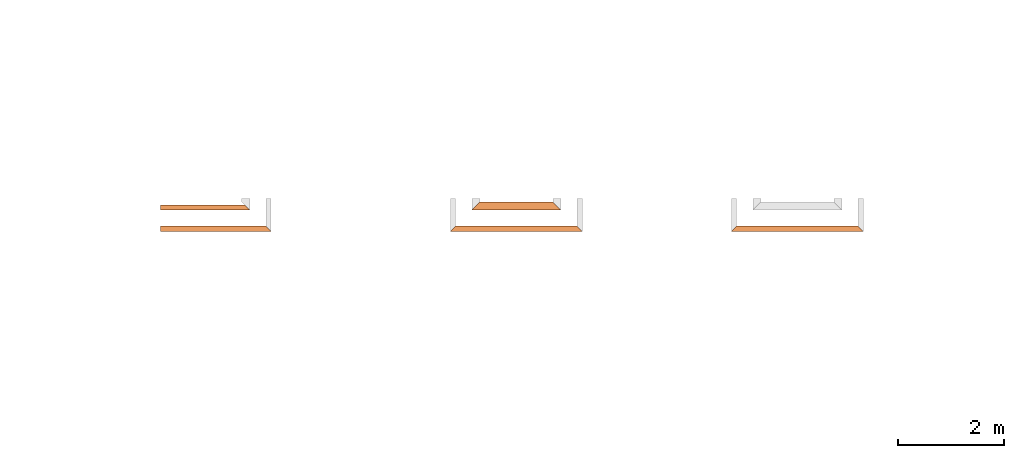
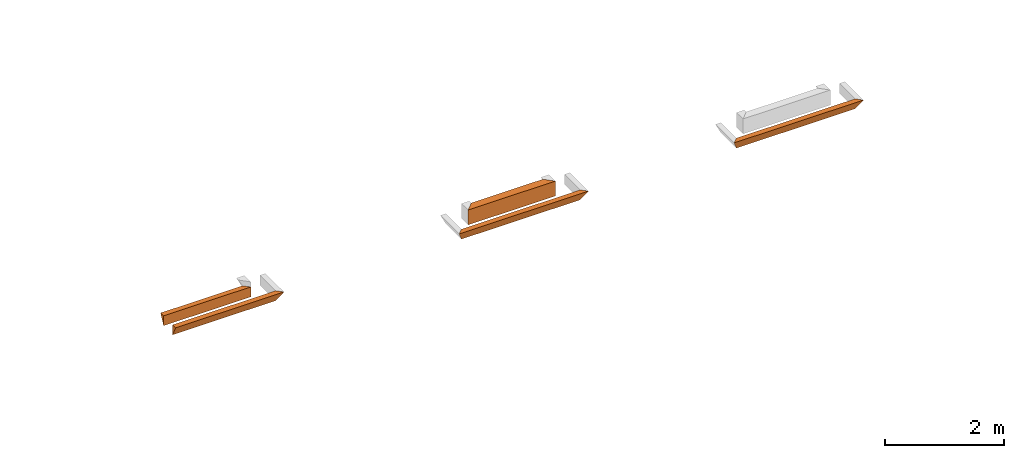
# One storey, part 2 of 8: 5 proxies.
"""IFC4 building model written with IfcOpenShell, lengths in feet."""

from ifc_helpers import new_model, entity, si_unit, converted_unit, derived_unit, direction, frame, origin, place, context, subcontext, project, spatial, type_object, element, save


model = new_model("IFC4")

# Units and contexts
model_context_1 = context("Model", 3, precision=0.0001, world=origin(), true_north=direction((6.12303176911189e-17, 1.0)))
model_context_2 = context("Model", 3, precision=0.0001, world=origin(), true_north=direction((6.12303176911189e-17, 1.0)))
body_context = subcontext(model_context_2, "Body", "Model", "MODEL_VIEW")
ifc_project = project(units=[converted_unit("LENGTHUNIT", "FOOT", entity("IfcRatioMeasure", 0.3048), si_unit("LENGTHUNIT", "METRE"), dimensions=[1, 0, 0, 0, 0, 0, 0]), converted_unit("AREAUNIT", "SQUARE FOOT", entity("IfcRatioMeasure", 0.09290304), si_unit("AREAUNIT", "SQUARE_METRE"), dimensions=[2, 0, 0, 0, 0, 0, 0]), converted_unit("VOLUMEUNIT", "CUBIC FOOT", entity("IfcRatioMeasure", 0.028316846592), si_unit("VOLUMEUNIT", "CUBIC_METRE"), dimensions=[3, 0, 0, 0, 0, 0, 0]), converted_unit("PLANEANGLEUNIT", "DEGREE", entity("IfcRatioMeasure", 0.0174532925199433), si_unit("PLANEANGLEUNIT", "RADIAN"), dimensions=[0, 0, 0, 0, 0, 0, 0]), si_unit("MASSUNIT", "GRAM", prefix="KILO"), derived_unit("MASSDENSITYUNIT", [(si_unit("MASSUNIT", "GRAM", prefix="KILO"), 1), (si_unit("LENGTHUNIT", "METRE"), -3)]), derived_unit("MOMENTOFINERTIAUNIT", [(si_unit("LENGTHUNIT", "METRE"), 4)]), si_unit("TIMEUNIT", "SECOND"), si_unit("FREQUENCYUNIT", "HERTZ"), si_unit("THERMODYNAMICTEMPERATUREUNIT", "DEGREE_CELSIUS"), derived_unit("THERMALTRANSMITTANCEUNIT", [(si_unit("MASSUNIT", "GRAM", prefix="KILO"), 1), (si_unit("THERMODYNAMICTEMPERATUREUNIT", "KELVIN"), -1), (si_unit("TIMEUNIT", "SECOND"), -3)]), derived_unit("VOLUMETRICFLOWRATEUNIT", [(si_unit("LENGTHUNIT", "METRE"), 3), (si_unit("TIMEUNIT", "SECOND"), -1)]), si_unit("ELECTRICCURRENTUNIT", "AMPERE"), si_unit("ELECTRICVOLTAGEUNIT", "VOLT"), si_unit("POWERUNIT", "WATT"), si_unit("FORCEUNIT", "NEWTON"), si_unit("ILLUMINANCEUNIT", "LUX"), si_unit("LUMINOUSFLUXUNIT", "LUMEN"), si_unit("LUMINOUSINTENSITYUNIT", "CANDELA"), derived_unit("USERDEFINED", [(si_unit("MASSUNIT", "GRAM", prefix="KILO"), -1), (si_unit("LENGTHUNIT", "METRE"), -2), (si_unit("TIMEUNIT", "SECOND"), 3), (si_unit("LUMINOUSFLUXUNIT", "LUMEN"), 1)]), derived_unit("LINEARVELOCITYUNIT", [(si_unit("LENGTHUNIT", "METRE"), 1), (si_unit("TIMEUNIT", "SECOND"), -1)]), si_unit("PRESSUREUNIT", "PASCAL"), derived_unit("USERDEFINED", [(si_unit("LENGTHUNIT", "METRE"), -2), (si_unit("MASSUNIT", "GRAM", prefix="KILO"), 1), (si_unit("TIMEUNIT", "SECOND"), -2)]), derived_unit("LINEARFORCEUNIT", [(si_unit("MASSUNIT", "GRAM", prefix="KILO"), 1), (si_unit("LENGTHUNIT", "METRE"), 1), (si_unit("TIMEUNIT", "SECOND"), -2), (si_unit("LENGTHUNIT", "METRE"), -1)]), derived_unit("PLANARFORCEUNIT", [(si_unit("MASSUNIT", "GRAM", prefix="KILO"), 1), (si_unit("LENGTHUNIT", "METRE"), 1), (si_unit("TIMEUNIT", "SECOND"), -2), (si_unit("LENGTHUNIT", "METRE"), -2)])], contexts=[model_context_1])

# Site, building, storey
site_placement = place(None, origin())
site = spatial("IfcSite", under=ifc_project, at=site_placement, CompositionType="ELEMENT")
building_placement = place(site_placement, origin())
building = spatial("IfcBuilding", under=site, at=building_placement, CompositionType="ELEMENT")
storey_placement = place(building_placement, frame((0.0, 0.0, -12.6666666666667)))
storey = spatial("IfcBuildingStorey", under=building, at=storey_placement, Name="BASEMENT", CompositionType="ELEMENT", Elevation=-12.6666666666667)

# Proxies
building_element_proxy_type_1 = type_object("IfcBuildingElementProxyType", PredefinedType="NOTDEFINED")
proxy_1_placement = place(storey_placement, frame((-253.238160457323, 957.231726549317, 11.5833333333333)))
cartesian_point_1 = entity("IfcCartesianPoint", [5.54166663846127, 0.0, 0.0])
vertex_point_1 = entity("IfcVertexPoint", cartesian_point_1)
cartesian_point_2 = entity("IfcCartesianPoint", [5.21181447152242, 0.329852166938849, 0.65970433387773])
vertex_point_2 = entity("IfcVertexPoint", cartesian_point_2)
edge_curve_1 = entity("IfcEdgeCurve", vertex_point_1, vertex_point_2, entity("IfcTrimmedCurve", entity("IfcLine", cartesian_point_1, entity("IfcVector", entity("IfcDirection", [-0.408248290463852, 0.408248290463852, 0.816496580927737]), 1.0)), [cartesian_point_1], [cartesian_point_2], True, "CARTESIAN"), True)
cartesian_point_3 = entity("IfcCartesianPoint", [5.54166663846115, 0.0, 0.666576254022283])
vertex_point_3 = entity("IfcVertexPoint", cartesian_point_3)
edge_curve_2 = entity("IfcEdgeCurve", vertex_point_2, vertex_point_3, entity("IfcTrimmedCurve", entity("IfcLine", cartesian_point_2, entity("IfcVector", entity("IfcDirection", [0.707030067676022, -0.707030067676022, 0.0147297930765838]), 1.0)), [cartesian_point_2], [cartesian_point_3], True, "CARTESIAN"), True)
edge_curve_3 = entity("IfcEdgeCurve", vertex_point_3, vertex_point_1, entity("IfcTrimmedCurve", entity("IfcLine", cartesian_point_3, entity("IfcVector", entity("IfcDirection", [0.0, 0.0, -1.0]), 1.0)), [cartesian_point_3], [cartesian_point_1], True, "CARTESIAN"), True)
cartesian_point_4 = entity("IfcCartesianPoint", [0.0, 0.329852166939077, 0.659704333877725])
vertex_point_4 = entity("IfcVertexPoint", cartesian_point_4)
cartesian_point_5 = entity("IfcCartesianPoint", [0.0, 0.0, 0.0])
vertex_point_5 = entity("IfcVertexPoint", cartesian_point_5)
edge_curve_4 = entity("IfcEdgeCurve", vertex_point_4, vertex_point_5, entity("IfcTrimmedCurve", entity("IfcLine", cartesian_point_4, entity("IfcVector", entity("IfcDirection", [0.0, -0.447213595499946, -0.894427190999922]), 1.0)), [cartesian_point_4], [cartesian_point_5], True, "CARTESIAN"), True)
cartesian_point_6 = entity("IfcCartesianPoint", [0.0, 0.0, 0.666576254022285])
vertex_point_6 = entity("IfcVertexPoint", cartesian_point_6)
edge_curve_5 = entity("IfcEdgeCurve", vertex_point_5, vertex_point_6, entity("IfcTrimmedCurve", entity("IfcLine", cartesian_point_5, entity("IfcVector", entity("IfcDirection", [0.0, 0.0, 1.0]), 1.0)), [cartesian_point_5], [cartesian_point_6], True, "CARTESIAN"), True)
edge_curve_6 = entity("IfcEdgeCurve", vertex_point_6, vertex_point_4, entity("IfcTrimmedCurve", entity("IfcLine", cartesian_point_6, entity("IfcVector", entity("IfcDirection", [0.0, 0.999783056728112, -0.0208288136818321]), 1.0)), [cartesian_point_6], [cartesian_point_4], True, "CARTESIAN"), True)
ifc_direction_1 = entity("IfcDirection", [-1.0, 0.0, 0.0])
ifc_direction_2 = entity("IfcDirection", [0.0, -1.0, 0.0])
edge_curve_7 = entity("IfcEdgeCurve", vertex_point_1, vertex_point_5, entity("IfcTrimmedCurve", entity("IfcLine", cartesian_point_1, entity("IfcVector", ifc_direction_1, 1.0)), [cartesian_point_1], [cartesian_point_5], True, "CARTESIAN"), True)
edge_curve_8 = entity("IfcEdgeCurve", vertex_point_4, vertex_point_2, entity("IfcTrimmedCurve", entity("IfcLine", cartesian_point_4, entity("IfcVector", entity("IfcDirection", [1.0, 0.0, 0.0]), 1.0)), [cartesian_point_4], [cartesian_point_2], True, "CARTESIAN"), True)
edge_curve_9 = entity("IfcEdgeCurve", vertex_point_3, vertex_point_6, entity("IfcTrimmedCurve", entity("IfcLine", cartesian_point_3, entity("IfcVector", ifc_direction_1, 1.0)), [cartesian_point_3], [cartesian_point_6], True, "CARTESIAN"), True)
element("IfcBuildingElementProxy", 1, at=proxy_1_placement, inside=storey, type_object=building_element_proxy_type_1, PredefinedType="NOTDEFINED", context=body_context, shape_type="AdvancedBrep", body=[
    entity("IfcAdvancedBrep", entity("IfcClosedShell", [entity("IfcAdvancedFace", [entity("IfcFaceOuterBound", entity("IfcEdgeLoop", [entity("IfcOrientedEdge", None, None, edge_curve_1, True), entity("IfcOrientedEdge", None, None, edge_curve_2, True), entity("IfcOrientedEdge", None, None, edge_curve_3, True)]), True)], entity("IfcPlane", entity("IfcAxis2Placement3D", entity("IfcCartesianPoint", [5.54166663846127, 0.0, 2.0]), entity("IfcDirection", [0.707106781186562, 0.707106781186533, 0.0]), entity("IfcDirection", [-0.707106781186533, 0.707106781186562, 0.0]))), True), entity("IfcAdvancedFace", [entity("IfcFaceOuterBound", entity("IfcEdgeLoop", [entity("IfcOrientedEdge", None, None, edge_curve_4, True), entity("IfcOrientedEdge", None, None, edge_curve_5, True), entity("IfcOrientedEdge", None, None, edge_curve_6, True)]), True)], entity("IfcPlane", entity("IfcAxis2Placement3D", cartesian_point_5, ifc_direction_1, ifc_direction_2)), True), entity("IfcAdvancedFace", [entity("IfcFaceOuterBound", entity("IfcEdgeLoop", [entity("IfcOrientedEdge", None, None, edge_curve_7, True), entity("IfcOrientedEdge", None, None, edge_curve_4, False), entity("IfcOrientedEdge", None, None, edge_curve_8, True), entity("IfcOrientedEdge", None, None, edge_curve_1, False)]), True)], entity("IfcPlane", entity("IfcAxis2Placement3D", cartesian_point_1, entity("IfcDirection", [0.0, 0.894427190999915, -0.447213595499961]), ifc_direction_1)), True), entity("IfcAdvancedFace", [entity("IfcFaceOuterBound", entity("IfcEdgeLoop", [entity("IfcOrientedEdge", None, None, edge_curve_7, False), entity("IfcOrientedEdge", None, None, edge_curve_3, False), entity("IfcOrientedEdge", None, None, edge_curve_9, True), entity("IfcOrientedEdge", None, None, edge_curve_5, False)]), True)], entity("IfcPlane", entity("IfcAxis2Placement3D", entity("IfcCartesianPoint", [5.54166663846127, 0.0, 1.0]), ifc_direction_2, ifc_direction_1)), True), entity("IfcAdvancedFace", [entity("IfcFaceOuterBound", entity("IfcEdgeLoop", [entity("IfcOrientedEdge", None, None, edge_curve_2, False), entity("IfcOrientedEdge", None, None, edge_curve_8, False), entity("IfcOrientedEdge", None, None, edge_curve_6, False), entity("IfcOrientedEdge", None, None, edge_curve_9, False)]), True)], entity("IfcPlane", entity("IfcAxis2Placement3D", cartesian_point_6, entity("IfcDirection", [0.0, 0.0208288136818357, 0.999783056728112]), entity("IfcDirection", [0.0, -0.999783056728112, 0.0208288136818357]))), True)])),
])
building_element_proxy_type_2 = type_object("IfcBuildingElementProxyType", PredefinedType="NOTDEFINED")
proxy_2_placement = place(storey_placement, frame((-253.238160457323, 955.897091132651, 11.5833333333333)))
cartesian_point_7 = entity("IfcCartesianPoint", [6.54166663846127, 0.334635416666742, 0.0])
vertex_point_7 = entity("IfcVertexPoint", cartesian_point_7)
cartesian_point_8 = entity("IfcCartesianPoint", [6.54166663846127, 0.334635416666742, 0.669270833333334])
vertex_point_8 = entity("IfcVertexPoint", cartesian_point_8)
ifc_direction_3 = entity("IfcDirection", [0.0, 0.0, 1.0])
edge_curve_10 = entity("IfcEdgeCurve", vertex_point_7, vertex_point_8, entity("IfcTrimmedCurve", entity("IfcLine", cartesian_point_7, entity("IfcVector", ifc_direction_3, 1.0)), [cartesian_point_7], [cartesian_point_8], True, "CARTESIAN"), True)
cartesian_point_9 = entity("IfcCartesianPoint", [6.87630205512772, 0.0, 0.669270833333334])
vertex_point_9 = entity("IfcVertexPoint", cartesian_point_9)
edge_curve_11 = entity("IfcEdgeCurve", vertex_point_8, vertex_point_9, entity("IfcTrimmedCurve", entity("IfcLine", cartesian_point_8, entity("IfcVector", entity("IfcDirection", [0.707106781186427, -0.707106781186668, 0.0]), 1.0)), [cartesian_point_8], [cartesian_point_9], True, "CARTESIAN"), True)
edge_curve_12 = entity("IfcEdgeCurve", vertex_point_9, vertex_point_7, entity("IfcTrimmedCurve", entity("IfcLine", cartesian_point_9, entity("IfcVector", entity("IfcDirection", [-0.408248290463863, 0.408248290463829, -0.816496580927743]), 1.0)), [cartesian_point_9], [cartesian_point_7], True, "CARTESIAN"), True)
cartesian_point_10 = entity("IfcCartesianPoint", [0.0, 0.33463541666697, 0.0])
vertex_point_10 = entity("IfcVertexPoint", cartesian_point_10)
cartesian_point_11 = entity("IfcCartesianPoint", [0.0, 0.0, 0.669270833333334])
vertex_point_11 = entity("IfcVertexPoint", cartesian_point_11)
edge_curve_13 = entity("IfcEdgeCurve", vertex_point_10, vertex_point_11, entity("IfcTrimmedCurve", entity("IfcLine", cartesian_point_10, entity("IfcVector", entity("IfcDirection", [0.0, -0.44721359549992, 0.894427190999935]), 1.0)), [cartesian_point_10], [cartesian_point_11], True, "CARTESIAN"), True)
cartesian_point_12 = entity("IfcCartesianPoint", [0.0, 0.33463541666697, 0.669270833333334])
vertex_point_12 = entity("IfcVertexPoint", cartesian_point_12)
ifc_direction_4 = entity("IfcDirection", [0.0, 1.0, 0.0])
edge_curve_14 = entity("IfcEdgeCurve", vertex_point_11, vertex_point_12, entity("IfcTrimmedCurve", entity("IfcLine", cartesian_point_11, entity("IfcVector", ifc_direction_4, 1.0)), [cartesian_point_11], [cartesian_point_12], True, "CARTESIAN"), True)
edge_curve_15 = entity("IfcEdgeCurve", vertex_point_12, vertex_point_10, entity("IfcTrimmedCurve", entity("IfcLine", cartesian_point_12, entity("IfcVector", entity("IfcDirection", [0.0, 0.0, -1.0]), 1.0)), [cartesian_point_12], [cartesian_point_10], True, "CARTESIAN"), True)
ifc_direction_5 = entity("IfcDirection", [-1.0, 0.0, 0.0])
edge_curve_16 = entity("IfcEdgeCurve", vertex_point_7, vertex_point_10, entity("IfcTrimmedCurve", entity("IfcLine", cartesian_point_7, entity("IfcVector", ifc_direction_5, 1.0)), [cartesian_point_7], [cartesian_point_10], True, "CARTESIAN"), True)
cartesian_point_13 = entity("IfcCartesianPoint", [5.54166663846127, 0.334635416666742, 0.669270833333334])
vertex_point_13 = entity("IfcVertexPoint", cartesian_point_13)
ifc_direction_6 = entity("IfcDirection", [1.0, 0.0, 0.0])
edge_curve_17 = entity("IfcEdgeCurve", vertex_point_12, vertex_point_13, entity("IfcTrimmedCurve", entity("IfcLine", cartesian_point_12, entity("IfcVector", ifc_direction_6, 1.0)), [cartesian_point_12], [cartesian_point_13], True, "CARTESIAN"), True)
edge_curve_18 = entity("IfcEdgeCurve", vertex_point_13, vertex_point_8, entity("IfcTrimmedCurve", entity("IfcLine", cartesian_point_13, entity("IfcVector", ifc_direction_6, 1.0)), [cartesian_point_13], [cartesian_point_8], True, "CARTESIAN"), True)
edge_curve_19 = entity("IfcEdgeCurve", vertex_point_9, vertex_point_11, entity("IfcTrimmedCurve", entity("IfcLine", cartesian_point_9, entity("IfcVector", ifc_direction_5, 1.0)), [cartesian_point_9], [cartesian_point_11], True, "CARTESIAN"), True)
element("IfcBuildingElementProxy", 2, at=proxy_2_placement, inside=storey, type_object=building_element_proxy_type_2, PredefinedType="NOTDEFINED", context=body_context, shape_type="AdvancedBrep", body=[
    entity("IfcAdvancedBrep", entity("IfcClosedShell", [entity("IfcAdvancedFace", [entity("IfcFaceOuterBound", entity("IfcEdgeLoop", [entity("IfcOrientedEdge", None, None, edge_curve_10, True), entity("IfcOrientedEdge", None, None, edge_curve_11, True), entity("IfcOrientedEdge", None, None, edge_curve_12, True)]), True)], entity("IfcPlane", entity("IfcAxis2Placement3D", entity("IfcCartesianPoint", [6.54166663846127, 0.334635416666742, 2.0]), entity("IfcDirection", [0.707106781186562, 0.707106781186533, 0.0]), entity("IfcDirection", [-0.707106781186533, 0.707106781186562, 0.0]))), True), entity("IfcAdvancedFace", [entity("IfcFaceOuterBound", entity("IfcEdgeLoop", [entity("IfcOrientedEdge", None, None, edge_curve_13, True), entity("IfcOrientedEdge", None, None, edge_curve_14, True), entity("IfcOrientedEdge", None, None, edge_curve_15, True)]), True)], entity("IfcPlane", entity("IfcAxis2Placement3D", cartesian_point_10, ifc_direction_5, entity("IfcDirection", [0.0, -1.0, 0.0]))), True), entity("IfcAdvancedFace", [entity("IfcFaceOuterBound", entity("IfcEdgeLoop", [entity("IfcOrientedEdge", None, None, edge_curve_16, True), entity("IfcOrientedEdge", None, None, edge_curve_15, False), entity("IfcOrientedEdge", None, None, edge_curve_17, True), entity("IfcOrientedEdge", None, None, edge_curve_18, True), entity("IfcOrientedEdge", None, None, edge_curve_10, False)]), True)], entity("IfcPlane", entity("IfcAxis2Placement3D", cartesian_point_7, ifc_direction_4, ifc_direction_5)), True), entity("IfcAdvancedFace", [entity("IfcFaceOuterBound", entity("IfcEdgeLoop", [entity("IfcOrientedEdge", None, None, edge_curve_16, False), entity("IfcOrientedEdge", None, None, edge_curve_12, False), entity("IfcOrientedEdge", None, None, edge_curve_19, True), entity("IfcOrientedEdge", None, None, edge_curve_13, False)]), True)], entity("IfcPlane", entity("IfcAxis2Placement3D", entity("IfcCartesianPoint", [7.04166663846127, -0.165364583333258, 1.0]), entity("IfcDirection", [0.0, -0.894427190999915, -0.447213595499961]), ifc_direction_5)), True), entity("IfcAdvancedFace", [entity("IfcFaceOuterBound", entity("IfcEdgeLoop", [entity("IfcOrientedEdge", None, None, edge_curve_11, False), entity("IfcOrientedEdge", None, None, edge_curve_18, False), entity("IfcOrientedEdge", None, None, edge_curve_17, False), entity("IfcOrientedEdge", None, None, edge_curve_14, False), entity("IfcOrientedEdge", None, None, edge_curve_19, False)]), True)], entity("IfcPlane", entity("IfcAxis2Placement3D", entity("IfcCartesianPoint", [111.500007646349, 2.96484375, 0.669270833333334]), ifc_direction_3, ifc_direction_6)), True)])),
])
building_element_proxy_type_3 = type_object("IfcBuildingElementProxyType", PredefinedType="NOTDEFINED")
proxy_3_placement = place(storey_placement, frame((-217.781129556124, 955.897091132649, 11.5833333333333)))
cartesian_point_14 = entity("IfcCartesianPoint", [7.87630257138792, 0.334635416666629, 0.0])
vertex_point_14 = entity("IfcVertexPoint", cartesian_point_14)
cartesian_point_15 = entity("IfcCartesianPoint", [7.87630257138792, 0.334635416666629, 0.669270833333334])
vertex_point_15 = entity("IfcVertexPoint", cartesian_point_15)
ifc_direction_7 = entity("IfcDirection", [0.0, 0.0, 1.0])
edge_curve_20 = entity("IfcEdgeCurve", vertex_point_14, vertex_point_15, entity("IfcTrimmedCurve", entity("IfcLine", cartesian_point_14, entity("IfcVector", ifc_direction_7, 1.0)), [cartesian_point_14], [cartesian_point_15], True, "CARTESIAN"), True)
cartesian_point_16 = entity("IfcCartesianPoint", [8.21093798805447, 0.0, 0.669270833333334])
vertex_point_16 = entity("IfcVertexPoint", cartesian_point_16)
edge_curve_21 = entity("IfcEdgeCurve", vertex_point_15, vertex_point_16, entity("IfcTrimmedCurve", entity("IfcLine", cartesian_point_15, entity("IfcVector", entity("IfcDirection", [0.707106781186548, -0.707106781186548, 0.0]), 1.0)), [cartesian_point_15], [cartesian_point_16], True, "CARTESIAN"), True)
edge_curve_22 = entity("IfcEdgeCurve", vertex_point_16, vertex_point_14, entity("IfcTrimmedCurve", entity("IfcLine", cartesian_point_16, entity("IfcVector", entity("IfcDirection", [-0.408248290463863, 0.408248290463829, -0.816496580927743]), 1.0)), [cartesian_point_16], [cartesian_point_14], True, "CARTESIAN"), True)
cartesian_point_17 = entity("IfcCartesianPoint", [0.334635416666714, 0.33463541666697, 0.0])
vertex_point_17 = entity("IfcVertexPoint", cartesian_point_17)
cartesian_point_18 = entity("IfcCartesianPoint", [0.0, 0.0, 0.669270833333334])
vertex_point_18 = entity("IfcVertexPoint", cartesian_point_18)
edge_curve_23 = entity("IfcEdgeCurve", vertex_point_17, vertex_point_18, entity("IfcTrimmedCurve", entity("IfcLine", cartesian_point_17, entity("IfcVector", entity("IfcDirection", [-0.408248290463863, -0.408248290463829, 0.816496580927743]), 1.0)), [cartesian_point_17], [cartesian_point_18], True, "CARTESIAN"), True)
cartesian_point_19 = entity("IfcCartesianPoint", [0.334635416666714, 0.33463541666697, 0.669270833333334])
vertex_point_19 = entity("IfcVertexPoint", cartesian_point_19)
edge_curve_24 = entity("IfcEdgeCurve", vertex_point_18, vertex_point_19, entity("IfcTrimmedCurve", entity("IfcLine", cartesian_point_18, entity("IfcVector", entity("IfcDirection", [0.707106781186517, 0.707106781186578, 0.0]), 1.0)), [cartesian_point_18], [cartesian_point_19], True, "CARTESIAN"), True)
edge_curve_25 = entity("IfcEdgeCurve", vertex_point_19, vertex_point_17, entity("IfcTrimmedCurve", entity("IfcLine", cartesian_point_19, entity("IfcVector", entity("IfcDirection", [0.0, 0.0, -1.0]), 1.0)), [cartesian_point_19], [cartesian_point_17], True, "CARTESIAN"), True)
ifc_direction_8 = entity("IfcDirection", [-1.0, 0.0, 0.0])
edge_curve_26 = entity("IfcEdgeCurve", vertex_point_14, vertex_point_17, entity("IfcTrimmedCurve", entity("IfcLine", cartesian_point_14, entity("IfcVector", ifc_direction_8, 1.0)), [cartesian_point_14], [cartesian_point_17], True, "CARTESIAN"), True)
cartesian_point_20 = entity("IfcCartesianPoint", [1.3346354166666, 0.33463541666697, 0.669270833333334])
vertex_point_20 = entity("IfcVertexPoint", cartesian_point_20)
ifc_direction_9 = entity("IfcDirection", [1.0, 0.0, 0.0])
edge_curve_27 = entity("IfcEdgeCurve", vertex_point_19, vertex_point_20, entity("IfcTrimmedCurve", entity("IfcLine", cartesian_point_19, entity("IfcVector", ifc_direction_9, 1.0)), [cartesian_point_19], [cartesian_point_20], True, "CARTESIAN"), True)
cartesian_point_21 = entity("IfcCartesianPoint", [4.45963573776979, 0.334635416666742, 0.669270833333334])
vertex_point_21 = entity("IfcVertexPoint", cartesian_point_21)
edge_curve_28 = entity("IfcEdgeCurve", vertex_point_20, vertex_point_21, entity("IfcTrimmedCurve", entity("IfcLine", cartesian_point_20, entity("IfcVector", ifc_direction_9, 1.0)), [cartesian_point_20], [cartesian_point_21], True, "CARTESIAN"), True)
cartesian_point_22 = entity("IfcCartesianPoint", [5.62630240443644, 0.334635416666742, 0.669270833333334])
vertex_point_22 = entity("IfcVertexPoint", cartesian_point_22)
edge_curve_29 = entity("IfcEdgeCurve", vertex_point_21, vertex_point_22, entity("IfcTrimmedCurve", entity("IfcLine", cartesian_point_21, entity("IfcVector", ifc_direction_9, 1.0)), [cartesian_point_21], [cartesian_point_22], True, "CARTESIAN"), True)
cartesian_point_23 = entity("IfcCartesianPoint", [6.87630257138792, 0.334635416666629, 0.669270833333334])
vertex_point_23 = entity("IfcVertexPoint", cartesian_point_23)
edge_curve_30 = entity("IfcEdgeCurve", vertex_point_22, vertex_point_23, entity("IfcTrimmedCurve", entity("IfcLine", cartesian_point_22, entity("IfcVector", ifc_direction_9, 1.0)), [cartesian_point_22], [cartesian_point_23], True, "CARTESIAN"), True)
edge_curve_31 = entity("IfcEdgeCurve", vertex_point_23, vertex_point_15, entity("IfcTrimmedCurve", entity("IfcLine", cartesian_point_23, entity("IfcVector", ifc_direction_9, 1.0)), [cartesian_point_23], [cartesian_point_15], True, "CARTESIAN"), True)
edge_curve_32 = entity("IfcEdgeCurve", vertex_point_16, vertex_point_18, entity("IfcTrimmedCurve", entity("IfcLine", cartesian_point_16, entity("IfcVector", ifc_direction_8, 1.0)), [cartesian_point_16], [cartesian_point_18], True, "CARTESIAN"), True)
element("IfcBuildingElementProxy", 3, at=proxy_3_placement, inside=storey, type_object=building_element_proxy_type_3, PredefinedType="NOTDEFINED", context=body_context, shape_type="AdvancedBrep", body=[
    entity("IfcAdvancedBrep", entity("IfcClosedShell", [entity("IfcAdvancedFace", [entity("IfcFaceOuterBound", entity("IfcEdgeLoop", [entity("IfcOrientedEdge", None, None, edge_curve_20, True), entity("IfcOrientedEdge", None, None, edge_curve_21, True), entity("IfcOrientedEdge", None, None, edge_curve_22, True)]), True)], entity("IfcPlane", entity("IfcAxis2Placement3D", entity("IfcCartesianPoint", [7.87630257138792, 0.334635416666629, 2.0]), entity("IfcDirection", [0.707106781186562, 0.707106781186533, 0.0]), entity("IfcDirection", [-0.707106781186533, 0.707106781186562, 0.0]))), True), entity("IfcAdvancedFace", [entity("IfcFaceOuterBound", entity("IfcEdgeLoop", [entity("IfcOrientedEdge", None, None, edge_curve_23, True), entity("IfcOrientedEdge", None, None, edge_curve_24, True), entity("IfcOrientedEdge", None, None, edge_curve_25, True)]), True)], entity("IfcPlane", entity("IfcAxis2Placement3D", entity("IfcCartesianPoint", [0.3346354166666, 0.334635416666856, 2.0]), entity("IfcDirection", [-0.707106781186548, 0.707106781186548, 0.0]), entity("IfcDirection", [0.707106781186548, 0.707106781186548, 0.0]))), True), entity("IfcAdvancedFace", [entity("IfcFaceOuterBound", entity("IfcEdgeLoop", [entity("IfcOrientedEdge", None, None, edge_curve_26, True), entity("IfcOrientedEdge", None, None, edge_curve_25, False), entity("IfcOrientedEdge", None, None, edge_curve_27, True), entity("IfcOrientedEdge", None, None, edge_curve_28, True), entity("IfcOrientedEdge", None, None, edge_curve_29, True), entity("IfcOrientedEdge", None, None, edge_curve_30, True), entity("IfcOrientedEdge", None, None, edge_curve_31, True), entity("IfcOrientedEdge", None, None, edge_curve_20, False)]), True)], entity("IfcPlane", entity("IfcAxis2Placement3D", cartesian_point_14, entity("IfcDirection", [0.0, 1.0, 0.0]), ifc_direction_8)), True), entity("IfcAdvancedFace", [entity("IfcFaceOuterBound", entity("IfcEdgeLoop", [entity("IfcOrientedEdge", None, None, edge_curve_26, False), entity("IfcOrientedEdge", None, None, edge_curve_22, False), entity("IfcOrientedEdge", None, None, edge_curve_32, True), entity("IfcOrientedEdge", None, None, edge_curve_23, False)]), True)], entity("IfcPlane", entity("IfcAxis2Placement3D", entity("IfcCartesianPoint", [8.37630257138792, -0.165364583333371, 1.0]), entity("IfcDirection", [0.0, -0.894427190999915, -0.447213595499961]), ifc_direction_8)), True), entity("IfcAdvancedFace", [entity("IfcFaceOuterBound", entity("IfcEdgeLoop", [entity("IfcOrientedEdge", None, None, edge_curve_21, False), entity("IfcOrientedEdge", None, None, edge_curve_31, False), entity("IfcOrientedEdge", None, None, edge_curve_30, False), entity("IfcOrientedEdge", None, None, edge_curve_29, False), entity("IfcOrientedEdge", None, None, edge_curve_28, False), entity("IfcOrientedEdge", None, None, edge_curve_27, False), entity("IfcOrientedEdge", None, None, edge_curve_24, False), entity("IfcOrientedEdge", None, None, edge_curve_32, False)]), True)], entity("IfcPlane", entity("IfcAxis2Placement3D", entity("IfcCartesianPoint", [76.0429767451503, 2.96484375000114, 0.669270833333334]), ifc_direction_7, ifc_direction_9)), True)])),
])
building_element_proxy_type_4 = type_object("IfcBuildingElementProxyType", PredefinedType="NOTDEFINED")
proxy_4_placement = place(storey_placement, frame((-235.239462736321, 955.89709113265, 11.5833333333333)))
cartesian_point_24 = entity("IfcCartesianPoint", [7.8763047862445, 0.334635416666629, 0.0])
vertex_point_24 = entity("IfcVertexPoint", cartesian_point_24)
cartesian_point_25 = entity("IfcCartesianPoint", [7.8763047862445, 0.334635416666629, 0.669270833333334])
vertex_point_25 = entity("IfcVertexPoint", cartesian_point_25)
ifc_direction_10 = entity("IfcDirection", [0.0, 0.0, 1.0])
edge_curve_33 = entity("IfcEdgeCurve", vertex_point_24, vertex_point_25, entity("IfcTrimmedCurve", entity("IfcLine", cartesian_point_24, entity("IfcVector", ifc_direction_10, 1.0)), [cartesian_point_24], [cartesian_point_25], True, "CARTESIAN"), True)
cartesian_point_26 = entity("IfcCartesianPoint", [8.21094020291105, 0.0, 0.669270833333334])
vertex_point_26 = entity("IfcVertexPoint", cartesian_point_26)
edge_curve_34 = entity("IfcEdgeCurve", vertex_point_25, vertex_point_26, entity("IfcTrimmedCurve", entity("IfcLine", cartesian_point_25, entity("IfcVector", entity("IfcDirection", [0.707106781186517, -0.707106781186578, 0.0]), 1.0)), [cartesian_point_25], [cartesian_point_26], True, "CARTESIAN"), True)
edge_curve_35 = entity("IfcEdgeCurve", vertex_point_26, vertex_point_24, entity("IfcTrimmedCurve", entity("IfcLine", cartesian_point_26, entity("IfcVector", entity("IfcDirection", [-0.408248290463863, 0.408248290463829, -0.816496580927743]), 1.0)), [cartesian_point_26], [cartesian_point_24], True, "CARTESIAN"), True)
cartesian_point_27 = entity("IfcCartesianPoint", [0.334635416666742, 0.33463541666697, 0.0])
vertex_point_27 = entity("IfcVertexPoint", cartesian_point_27)
cartesian_point_28 = entity("IfcCartesianPoint", [0.0, 0.0, 0.669270833333334])
vertex_point_28 = entity("IfcVertexPoint", cartesian_point_28)
edge_curve_36 = entity("IfcEdgeCurve", vertex_point_27, vertex_point_28, entity("IfcTrimmedCurve", entity("IfcLine", cartesian_point_27, entity("IfcVector", entity("IfcDirection", [-0.408248290463863, -0.408248290463829, 0.816496580927743]), 1.0)), [cartesian_point_27], [cartesian_point_28], True, "CARTESIAN"), True)
cartesian_point_29 = entity("IfcCartesianPoint", [0.334635416666742, 0.33463541666697, 0.669270833333334])
vertex_point_29 = entity("IfcVertexPoint", cartesian_point_29)
edge_curve_37 = entity("IfcEdgeCurve", vertex_point_28, vertex_point_29, entity("IfcTrimmedCurve", entity("IfcLine", cartesian_point_28, entity("IfcVector", entity("IfcDirection", [0.707106781186517, 0.707106781186578, 0.0]), 1.0)), [cartesian_point_28], [cartesian_point_29], True, "CARTESIAN"), True)
edge_curve_38 = entity("IfcEdgeCurve", vertex_point_29, vertex_point_27, entity("IfcTrimmedCurve", entity("IfcLine", cartesian_point_29, entity("IfcVector", entity("IfcDirection", [0.0, 0.0, -1.0]), 1.0)), [cartesian_point_29], [cartesian_point_27], True, "CARTESIAN"), True)
ifc_direction_11 = entity("IfcDirection", [-1.0, 0.0, 0.0])
edge_curve_39 = entity("IfcEdgeCurve", vertex_point_24, vertex_point_27, entity("IfcTrimmedCurve", entity("IfcLine", cartesian_point_24, entity("IfcVector", ifc_direction_11, 1.0)), [cartesian_point_24], [cartesian_point_27], True, "CARTESIAN"), True)
cartesian_point_30 = entity("IfcCartesianPoint", [1.33463541666663, 0.33463541666697, 0.669270833333334])
vertex_point_30 = entity("IfcVertexPoint", cartesian_point_30)
ifc_direction_12 = entity("IfcDirection", [1.0, 0.0, 0.0])
edge_curve_40 = entity("IfcEdgeCurve", vertex_point_29, vertex_point_30, entity("IfcTrimmedCurve", entity("IfcLine", cartesian_point_29, entity("IfcVector", ifc_direction_12, 1.0)), [cartesian_point_29], [cartesian_point_30], True, "CARTESIAN"), True)
cartesian_point_31 = entity("IfcCartesianPoint", [2.58463558470353, 0.334635416666856, 0.669270833333334])
vertex_point_31 = entity("IfcVertexPoint", cartesian_point_31)
edge_curve_41 = entity("IfcEdgeCurve", vertex_point_30, vertex_point_31, entity("IfcTrimmedCurve", entity("IfcLine", cartesian_point_30, entity("IfcVector", ifc_direction_12, 1.0)), [cartesian_point_30], [cartesian_point_31], True, "CARTESIAN"), True)
cartesian_point_32 = entity("IfcCartesianPoint", [3.75130225137019, 0.334635416666856, 0.669270833333334])
vertex_point_32 = entity("IfcVertexPoint", cartesian_point_32)
edge_curve_42 = entity("IfcEdgeCurve", vertex_point_31, vertex_point_32, entity("IfcTrimmedCurve", entity("IfcLine", cartesian_point_31, entity("IfcVector", ifc_direction_12, 1.0)), [cartesian_point_31], [cartesian_point_32], True, "CARTESIAN"), True)
cartesian_point_33 = entity("IfcCartesianPoint", [6.8763047862445, 0.334635416666629, 0.669270833333334])
vertex_point_33 = entity("IfcVertexPoint", cartesian_point_33)
edge_curve_43 = entity("IfcEdgeCurve", vertex_point_32, vertex_point_33, entity("IfcTrimmedCurve", entity("IfcLine", cartesian_point_32, entity("IfcVector", ifc_direction_12, 1.0)), [cartesian_point_32], [cartesian_point_33], True, "CARTESIAN"), True)
edge_curve_44 = entity("IfcEdgeCurve", vertex_point_33, vertex_point_25, entity("IfcTrimmedCurve", entity("IfcLine", cartesian_point_33, entity("IfcVector", ifc_direction_12, 1.0)), [cartesian_point_33], [cartesian_point_25], True, "CARTESIAN"), True)
edge_curve_45 = entity("IfcEdgeCurve", vertex_point_26, vertex_point_28, entity("IfcTrimmedCurve", entity("IfcLine", cartesian_point_26, entity("IfcVector", ifc_direction_11, 1.0)), [cartesian_point_26], [cartesian_point_28], True, "CARTESIAN"), True)
element("IfcBuildingElementProxy", 4, at=proxy_4_placement, inside=storey, type_object=building_element_proxy_type_4, PredefinedType="NOTDEFINED", context=body_context, shape_type="AdvancedBrep", body=[
    entity("IfcAdvancedBrep", entity("IfcClosedShell", [entity("IfcAdvancedFace", [entity("IfcFaceOuterBound", entity("IfcEdgeLoop", [entity("IfcOrientedEdge", None, None, edge_curve_33, True), entity("IfcOrientedEdge", None, None, edge_curve_34, True), entity("IfcOrientedEdge", None, None, edge_curve_35, True)]), True)], entity("IfcPlane", entity("IfcAxis2Placement3D", entity("IfcCartesianPoint", [7.8763047862445, 0.334635416666629, 2.0]), entity("IfcDirection", [0.707106781186562, 0.707106781186533, 0.0]), entity("IfcDirection", [-0.707106781186533, 0.707106781186562, 0.0]))), True), entity("IfcAdvancedFace", [entity("IfcFaceOuterBound", entity("IfcEdgeLoop", [entity("IfcOrientedEdge", None, None, edge_curve_36, True), entity("IfcOrientedEdge", None, None, edge_curve_37, True), entity("IfcOrientedEdge", None, None, edge_curve_38, True)]), True)], entity("IfcPlane", entity("IfcAxis2Placement3D", entity("IfcCartesianPoint", [0.334635416666629, 0.334635416666856, 2.0]), entity("IfcDirection", [-0.707106781186548, 0.707106781186548, 0.0]), entity("IfcDirection", [0.707106781186548, 0.707106781186548, 0.0]))), True), entity("IfcAdvancedFace", [entity("IfcFaceOuterBound", entity("IfcEdgeLoop", [entity("IfcOrientedEdge", None, None, edge_curve_39, True), entity("IfcOrientedEdge", None, None, edge_curve_38, False), entity("IfcOrientedEdge", None, None, edge_curve_40, True), entity("IfcOrientedEdge", None, None, edge_curve_41, True), entity("IfcOrientedEdge", None, None, edge_curve_42, True), entity("IfcOrientedEdge", None, None, edge_curve_43, True), entity("IfcOrientedEdge", None, None, edge_curve_44, True), entity("IfcOrientedEdge", None, None, edge_curve_33, False)]), True)], entity("IfcPlane", entity("IfcAxis2Placement3D", cartesian_point_24, entity("IfcDirection", [0.0, 1.0, 0.0]), ifc_direction_11)), True), entity("IfcAdvancedFace", [entity("IfcFaceOuterBound", entity("IfcEdgeLoop", [entity("IfcOrientedEdge", None, None, edge_curve_39, False), entity("IfcOrientedEdge", None, None, edge_curve_35, False), entity("IfcOrientedEdge", None, None, edge_curve_45, True), entity("IfcOrientedEdge", None, None, edge_curve_36, False)]), True)], entity("IfcPlane", entity("IfcAxis2Placement3D", entity("IfcCartesianPoint", [8.3763047862445, -0.165364583333371, 1.0]), entity("IfcDirection", [0.0, -0.894427190999915, -0.447213595499961]), ifc_direction_11)), True), entity("IfcAdvancedFace", [entity("IfcFaceOuterBound", entity("IfcEdgeLoop", [entity("IfcOrientedEdge", None, None, edge_curve_34, False), entity("IfcOrientedEdge", None, None, edge_curve_44, False), entity("IfcOrientedEdge", None, None, edge_curve_43, False), entity("IfcOrientedEdge", None, None, edge_curve_42, False), entity("IfcOrientedEdge", None, None, edge_curve_41, False), entity("IfcOrientedEdge", None, None, edge_curve_40, False), entity("IfcOrientedEdge", None, None, edge_curve_37, False), entity("IfcOrientedEdge", None, None, edge_curve_45, False)]), True)], entity("IfcPlane", entity("IfcAxis2Placement3D", entity("IfcCartesianPoint", [93.5013099253467, 2.96484375000057, 0.669270833333334]), ifc_direction_10, ifc_direction_12)), True)])),
])
building_element_proxy_type_5 = type_object("IfcBuildingElementProxyType", PredefinedType="NOTDEFINED")
proxy_5_placement = place(storey_placement, frame((-233.904827319654, 957.231726549317, 11.5833333333333)))
cartesian_point_34 = entity("IfcCartesianPoint", [5.5416693695779, 0.0, 0.0])
vertex_point_34 = entity("IfcVertexPoint", cartesian_point_34)
cartesian_point_35 = entity("IfcCartesianPoint", [5.0416693695779, 0.5, 1.0])
vertex_point_35 = entity("IfcVertexPoint", cartesian_point_35)
edge_curve_46 = entity("IfcEdgeCurve", vertex_point_34, vertex_point_35, entity("IfcTrimmedCurve", entity("IfcLine", cartesian_point_34, entity("IfcVector", entity("IfcDirection", [-0.408248290463864, 0.408248290463864, 0.816496580927725]), 1.0)), [cartesian_point_34], [cartesian_point_35], True, "CARTESIAN"), True)
cartesian_point_36 = entity("IfcCartesianPoint", [5.5416693695779, 0.0, 1.0])
vertex_point_36 = entity("IfcVertexPoint", cartesian_point_36)
edge_curve_47 = entity("IfcEdgeCurve", vertex_point_35, vertex_point_36, entity("IfcTrimmedCurve", entity("IfcLine", cartesian_point_35, entity("IfcVector", entity("IfcDirection", [0.707106781186547, -0.707106781186547, 0.0]), 1.0)), [cartesian_point_35], [cartesian_point_36], True, "CARTESIAN"), True)
cartesian_point_37 = entity("IfcCartesianPoint", [5.5416693695779, 0.0, 0.669270833333334])
vertex_point_37 = entity("IfcVertexPoint", cartesian_point_37)
ifc_direction_13 = entity("IfcDirection", [0.0, 0.0, -1.0])
edge_curve_48 = entity("IfcEdgeCurve", vertex_point_36, vertex_point_37, entity("IfcTrimmedCurve", entity("IfcLine", cartesian_point_36, entity("IfcVector", ifc_direction_13, 1.0)), [cartesian_point_36], [cartesian_point_37], True, "CARTESIAN"), True)
edge_curve_49 = entity("IfcEdgeCurve", vertex_point_37, vertex_point_34, entity("IfcTrimmedCurve", entity("IfcLine", cartesian_point_37, entity("IfcVector", ifc_direction_13, 1.0)), [cartesian_point_37], [cartesian_point_34], True, "CARTESIAN"), True)
cartesian_point_38 = entity("IfcCartesianPoint", [0.499999999999943, 0.500000000000227, 1.0])
vertex_point_38 = entity("IfcVertexPoint", cartesian_point_38)
cartesian_point_39 = entity("IfcCartesianPoint", [0.0, 0.0, 0.0])
vertex_point_39 = entity("IfcVertexPoint", cartesian_point_39)
edge_curve_50 = entity("IfcEdgeCurve", vertex_point_38, vertex_point_39, entity("IfcTrimmedCurve", entity("IfcLine", cartesian_point_38, entity("IfcVector", entity("IfcDirection", [-0.408248290463845, -0.408248290463868, -0.816496580927732]), 1.0)), [cartesian_point_38], [cartesian_point_39], True, "CARTESIAN"), True)
cartesian_point_40 = entity("IfcCartesianPoint", [0.0, 0.0, 0.669270833333334])
vertex_point_40 = entity("IfcVertexPoint", cartesian_point_40)
ifc_direction_14 = entity("IfcDirection", [0.0, 0.0, 1.0])
edge_curve_51 = entity("IfcEdgeCurve", vertex_point_39, vertex_point_40, entity("IfcTrimmedCurve", entity("IfcLine", cartesian_point_39, entity("IfcVector", ifc_direction_14, 1.0)), [cartesian_point_39], [cartesian_point_40], True, "CARTESIAN"), True)
cartesian_point_41 = entity("IfcCartesianPoint", [0.0, 0.0, 1.0])
vertex_point_41 = entity("IfcVertexPoint", cartesian_point_41)
edge_curve_52 = entity("IfcEdgeCurve", vertex_point_40, vertex_point_41, entity("IfcTrimmedCurve", entity("IfcLine", cartesian_point_40, entity("IfcVector", ifc_direction_14, 1.0)), [cartesian_point_40], [cartesian_point_41], True, "CARTESIAN"), True)
edge_curve_53 = entity("IfcEdgeCurve", vertex_point_41, vertex_point_38, entity("IfcTrimmedCurve", entity("IfcLine", cartesian_point_41, entity("IfcVector", entity("IfcDirection", [0.707106781186527, 0.707106781186568, 0.0]), 1.0)), [cartesian_point_41], [cartesian_point_38], True, "CARTESIAN"), True)
ifc_direction_15 = entity("IfcDirection", [-1.0, 0.0, 0.0])
edge_curve_54 = entity("IfcEdgeCurve", vertex_point_34, vertex_point_39, entity("IfcTrimmedCurve", entity("IfcLine", cartesian_point_34, entity("IfcVector", ifc_direction_15, 1.0)), [cartesian_point_34], [cartesian_point_39], True, "CARTESIAN"), True)
ifc_direction_16 = entity("IfcDirection", [1.0, 0.0, 0.0])
edge_curve_55 = entity("IfcEdgeCurve", vertex_point_38, vertex_point_35, entity("IfcTrimmedCurve", entity("IfcLine", cartesian_point_35, entity("IfcVector", ifc_direction_16, 1.0)), [cartesian_point_38], [cartesian_point_35], True, "CARTESIAN"), True)
edge_curve_56 = entity("IfcEdgeCurve", vertex_point_41, vertex_point_36, entity("IfcTrimmedCurve", entity("IfcLine", cartesian_point_36, entity("IfcVector", ifc_direction_16, 1.0)), [cartesian_point_41], [cartesian_point_36], True, "CARTESIAN"), True)
element("IfcBuildingElementProxy", 5, at=proxy_5_placement, inside=storey, type_object=building_element_proxy_type_5, PredefinedType="NOTDEFINED", context=body_context, shape_type="AdvancedBrep", body=[
    entity("IfcAdvancedBrep", entity("IfcClosedShell", [entity("IfcAdvancedFace", [entity("IfcFaceOuterBound", entity("IfcEdgeLoop", [entity("IfcOrientedEdge", None, None, edge_curve_46, True), entity("IfcOrientedEdge", None, None, edge_curve_47, True), entity("IfcOrientedEdge", None, None, edge_curve_48, True), entity("IfcOrientedEdge", None, None, edge_curve_49, True)]), True)], entity("IfcPlane", entity("IfcAxis2Placement3D", entity("IfcCartesianPoint", [5.5416693695779, 0.0, 2.0]), entity("IfcDirection", [0.707106781186562, 0.707106781186533, 0.0]), entity("IfcDirection", [-0.707106781186533, 0.707106781186562, 0.0]))), True), entity("IfcAdvancedFace", [entity("IfcFaceOuterBound", entity("IfcEdgeLoop", [entity("IfcOrientedEdge", None, None, edge_curve_50, True), entity("IfcOrientedEdge", None, None, edge_curve_51, True), entity("IfcOrientedEdge", None, None, edge_curve_52, True), entity("IfcOrientedEdge", None, None, edge_curve_53, True)]), True)], entity("IfcPlane", entity("IfcAxis2Placement3D", entity("IfcCartesianPoint", [0.0, 0.0, 2.0]), entity("IfcDirection", [-0.707106781186548, 0.707106781186548, 0.0]), entity("IfcDirection", [0.707106781186548, 0.707106781186548, 0.0]))), True), entity("IfcAdvancedFace", [entity("IfcFaceOuterBound", entity("IfcEdgeLoop", [entity("IfcOrientedEdge", None, None, edge_curve_46, False), entity("IfcOrientedEdge", None, None, edge_curve_54, True), entity("IfcOrientedEdge", None, None, edge_curve_50, False), entity("IfcOrientedEdge", None, None, edge_curve_55, True)]), True)], entity("IfcPlane", entity("IfcAxis2Placement3D", cartesian_point_34, entity("IfcDirection", [0.0, 0.894427190999915, -0.447213595499961]), ifc_direction_15)), True), entity("IfcAdvancedFace", [entity("IfcFaceOuterBound", entity("IfcEdgeLoop", [entity("IfcOrientedEdge", None, None, edge_curve_47, False), entity("IfcOrientedEdge", None, None, edge_curve_55, False), entity("IfcOrientedEdge", None, None, edge_curve_53, False), entity("IfcOrientedEdge", None, None, edge_curve_56, True)]), True)], entity("IfcPlane", entity("IfcAxis2Placement3D", cartesian_point_35, ifc_direction_14, ifc_direction_15)), True), entity("IfcAdvancedFace", [entity("IfcFaceOuterBound", entity("IfcEdgeLoop", [entity("IfcOrientedEdge", None, None, edge_curve_56, False), entity("IfcOrientedEdge", None, None, edge_curve_52, False), entity("IfcOrientedEdge", None, None, edge_curve_51, False), entity("IfcOrientedEdge", None, None, edge_curve_54, False), entity("IfcOrientedEdge", None, None, edge_curve_49, False), entity("IfcOrientedEdge", None, None, edge_curve_48, False)]), True)], entity("IfcPlane", entity("IfcAxis2Placement3D", cartesian_point_36, entity("IfcDirection", [0.0, -1.0, 0.0]), ifc_direction_15)), True)])),
])

save(model, "model.ifc")
